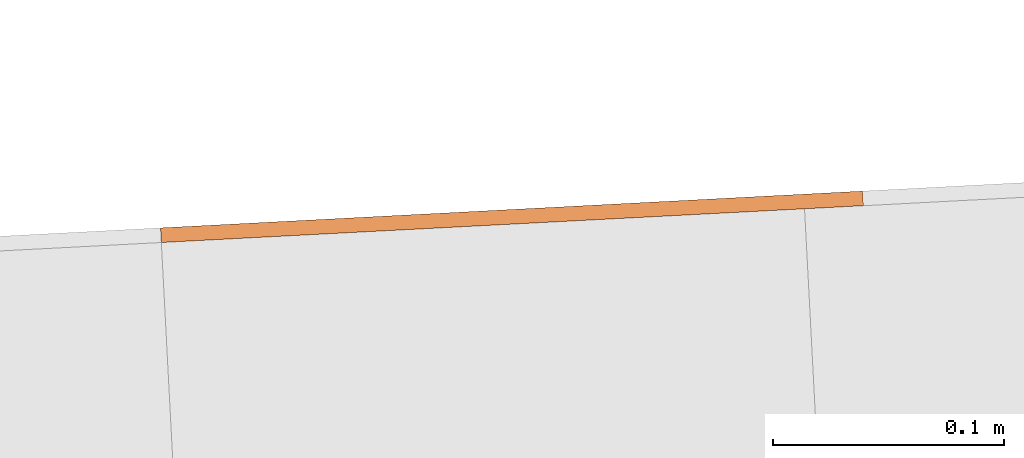
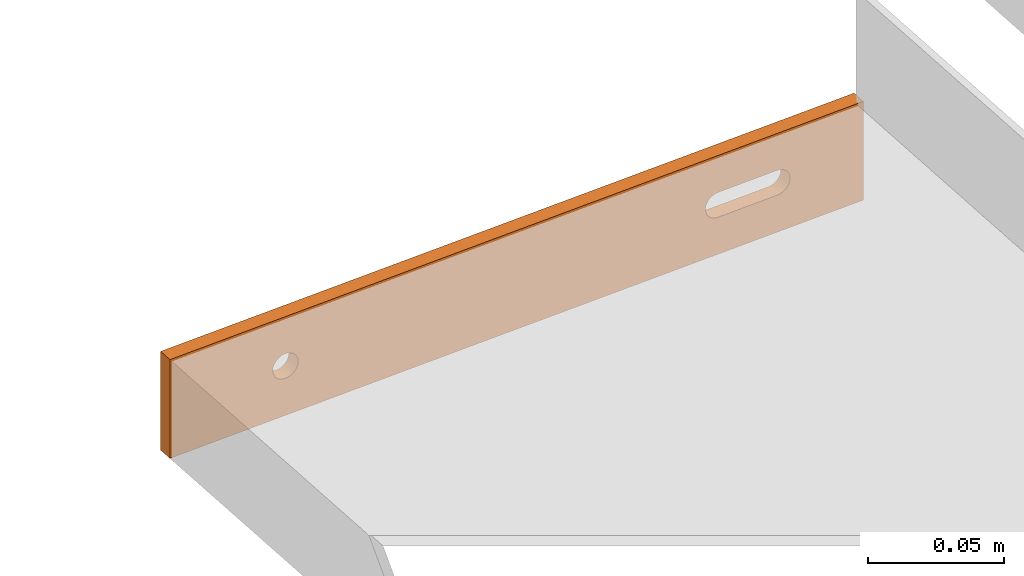
# One storey, part 23 of 23: 1 proxy.
"""IFC4 building model written with IfcOpenShell, lengths in feet."""

from ifc_helpers import new_model, entity, si_unit, converted_unit, derived_unit, direction, frame, frame_2d, origin, place, context, subcontext, project, spatial, polyline, circle_curve, parameter, trimmed, segment, composite_curve, outline, extrude, source, transform, mapped, material, type_object, type_shapes, element, save


model = new_model("IFC4")

# Units and contexts
model_context = context("Model", 3, precision=0.0001, world=origin(), true_north=direction((6.12303176911189e-17, 1.0)))
body_context = subcontext(model_context, "Body", "Model", "MODEL_VIEW")
ifc_project = project(units=[converted_unit("LENGTHUNIT", "FOOT", entity("IfcRatioMeasure", 0.3048), si_unit("LENGTHUNIT", "METRE"), dimensions=[1, 0, 0, 0, 0, 0, 0]), converted_unit("AREAUNIT", "SQUARE FOOT", entity("IfcRatioMeasure", 0.09290304), si_unit("AREAUNIT", "SQUARE_METRE"), dimensions=[2, 0, 0, 0, 0, 0, 0]), converted_unit("VOLUMEUNIT", "CUBIC FOOT", entity("IfcRatioMeasure", 0.028316846592), si_unit("VOLUMEUNIT", "CUBIC_METRE"), dimensions=[3, 0, 0, 0, 0, 0, 0]), converted_unit("PLANEANGLEUNIT", "DEGREE", entity("IfcRatioMeasure", 0.0174532925199433), si_unit("PLANEANGLEUNIT", "RADIAN"), dimensions=[0, 0, 0, 0, 0, 0, 0]), si_unit("MASSUNIT", "GRAM", prefix="KILO"), derived_unit("MASSDENSITYUNIT", [(si_unit("MASSUNIT", "GRAM", prefix="KILO"), 1), (si_unit("LENGTHUNIT", "METRE"), -3)]), derived_unit("MOMENTOFINERTIAUNIT", [(si_unit("LENGTHUNIT", "METRE"), 4)]), si_unit("TIMEUNIT", "SECOND"), si_unit("FREQUENCYUNIT", "HERTZ"), si_unit("THERMODYNAMICTEMPERATUREUNIT", "DEGREE_CELSIUS"), derived_unit("THERMALTRANSMITTANCEUNIT", [(si_unit("MASSUNIT", "GRAM", prefix="KILO"), 1), (si_unit("THERMODYNAMICTEMPERATUREUNIT", "KELVIN"), -1), (si_unit("TIMEUNIT", "SECOND"), -3)]), derived_unit("VOLUMETRICFLOWRATEUNIT", [(si_unit("LENGTHUNIT", "METRE"), 3), (si_unit("TIMEUNIT", "SECOND"), -1)]), si_unit("ELECTRICCURRENTUNIT", "AMPERE"), si_unit("ELECTRICVOLTAGEUNIT", "VOLT"), si_unit("POWERUNIT", "WATT"), si_unit("FORCEUNIT", "NEWTON"), si_unit("ILLUMINANCEUNIT", "LUX"), si_unit("LUMINOUSFLUXUNIT", "LUMEN"), si_unit("LUMINOUSINTENSITYUNIT", "CANDELA"), derived_unit("USERDEFINED", [(si_unit("MASSUNIT", "GRAM", prefix="KILO"), -1), (si_unit("LENGTHUNIT", "METRE"), -2), (si_unit("TIMEUNIT", "SECOND"), 3), (si_unit("LUMINOUSFLUXUNIT", "LUMEN"), 1)]), derived_unit("LINEARVELOCITYUNIT", [(si_unit("LENGTHUNIT", "METRE"), 1), (si_unit("TIMEUNIT", "SECOND"), -1)]), si_unit("PRESSUREUNIT", "PASCAL"), derived_unit("USERDEFINED", [(si_unit("LENGTHUNIT", "METRE"), -2), (si_unit("MASSUNIT", "GRAM", prefix="KILO"), 1), (si_unit("TIMEUNIT", "SECOND"), -2)]), derived_unit("LINEARFORCEUNIT", [(si_unit("MASSUNIT", "GRAM", prefix="KILO"), 1), (si_unit("LENGTHUNIT", "METRE"), 1), (si_unit("TIMEUNIT", "SECOND"), -2), (si_unit("LENGTHUNIT", "METRE"), -1)]), derived_unit("PLANARFORCEUNIT", [(si_unit("MASSUNIT", "GRAM", prefix="KILO"), 1), (si_unit("LENGTHUNIT", "METRE"), 1), (si_unit("TIMEUNIT", "SECOND"), -2), (si_unit("LENGTHUNIT", "METRE"), -2)])], contexts=[model_context])

# Site, building, storey
site_placement = place(None, origin())
site = spatial("IfcSite", under=ifc_project, at=site_placement, CompositionType="ELEMENT")
building_placement = place(site_placement, origin())
building = spatial("IfcBuilding", under=site, at=building_placement, CompositionType="ELEMENT")
storey_placement = place(building_placement, frame((0.0, 0.0, 10.8020833333333)))
storey = spatial("IfcBuildingStorey", under=building, at=storey_placement, Name="2ND FLOOR", CompositionType="ELEMENT", Elevation=10.8020833333333)

# Proxy
ifc_material = material(Name="GALV. STEEL TREAD", Category="Materials")
building_element_proxy_type = type_object("IfcBuildingElementProxyType", Name="Generic Models 764:Generic Models 629", PredefinedType="NOTDEFINED", material=ifc_material)
shared_shape = source(origin(), body_context, "Body", "SweptSolid", [
    extrude(outline(polyline([(-0.499999999999973, -0.0729166666666679), (0.499999999999967, -0.0729166666666679), (0.500000000000001, 0.0729166666666679), (-0.499999999999967, 0.0729166666666679), (-0.499999999999973, -0.0729166666666679)]), holes=[composite_curve([segment(trimmed(circle_curve(frame_2d((-0.33333333333333, 0.0), x_axis=(-1.0, 0.0)), 0.0182291666666717), [parameter(180.0)], [parameter(360.0)], True, "PARAMETER"), False, "CONTINUOUS"), segment(trimmed(circle_curve(frame_2d((-0.333333333333336, 0.0), x_axis=(-1.0, 0.0)), 0.0182291666666717), [parameter(360.0)], [parameter(180.0)], True, "PARAMETER"), False, "CONTINUOUS")], self_intersect=False), composite_curve([segment(polyline([(0.376206281053256, -0.018229166666675), (0.290460385613233, -0.0182291666667105)]), True, "CONTINUOUS"), segment(trimmed(circle_curve(frame_2d((0.290460385613233, 0.0), x_axis=(1.0, 0.0)), 0.0182291666666714), [parameter(89.999999999957)], [parameter(269.999999999957)], True, "PARAMETER"), False, "CONTINUOUS"), segment(polyline([(0.290460385613239, 0.0182291666666679), (0.376206281053228, 0.0182291666666679)]), True, "CONTINUOUS"), segment(trimmed(circle_curve(frame_2d((0.376206281053256, 0.0), x_axis=(-1.0, 0.0)), 0.0182291666666714), [parameter(90.0000000000894)], [parameter(270.000000000089)], True, "PARAMETER"), False, "CONTINUOUS")], self_intersect=False)]), frame((0.500405099798996, 0.0261679781215207, 0.0729166666666679), z_axis=(-0.0523359562429309, 0.998629534754575, 0.0), x_axis=(0.998629534754575, 0.0523359562429309, 0.0)), (0.0, 0.0, 1.0), 0.0208333333333866),
])
type_shapes(building_element_proxy_type, [shared_shape])
proxy_placement = place(storey_placement, frame((-167.223375856515, 968.956290201985, 9.22094298245626)))
element("IfcBuildingElementProxy", 1, at=proxy_placement, inside=storey, type_object=building_element_proxy_type, material=ifc_material, Name="Generic Models 764:Generic Models 629", ObjectType="Generic Models 764:Generic Models 629", PredefinedType="NOTDEFINED", context=body_context, shape_type="MappedRepresentation", body=[
    mapped(shared_shape, transform((0.0, 0.0, 0.0), scale=1.0)),
])

save(model, "model.ifc")
